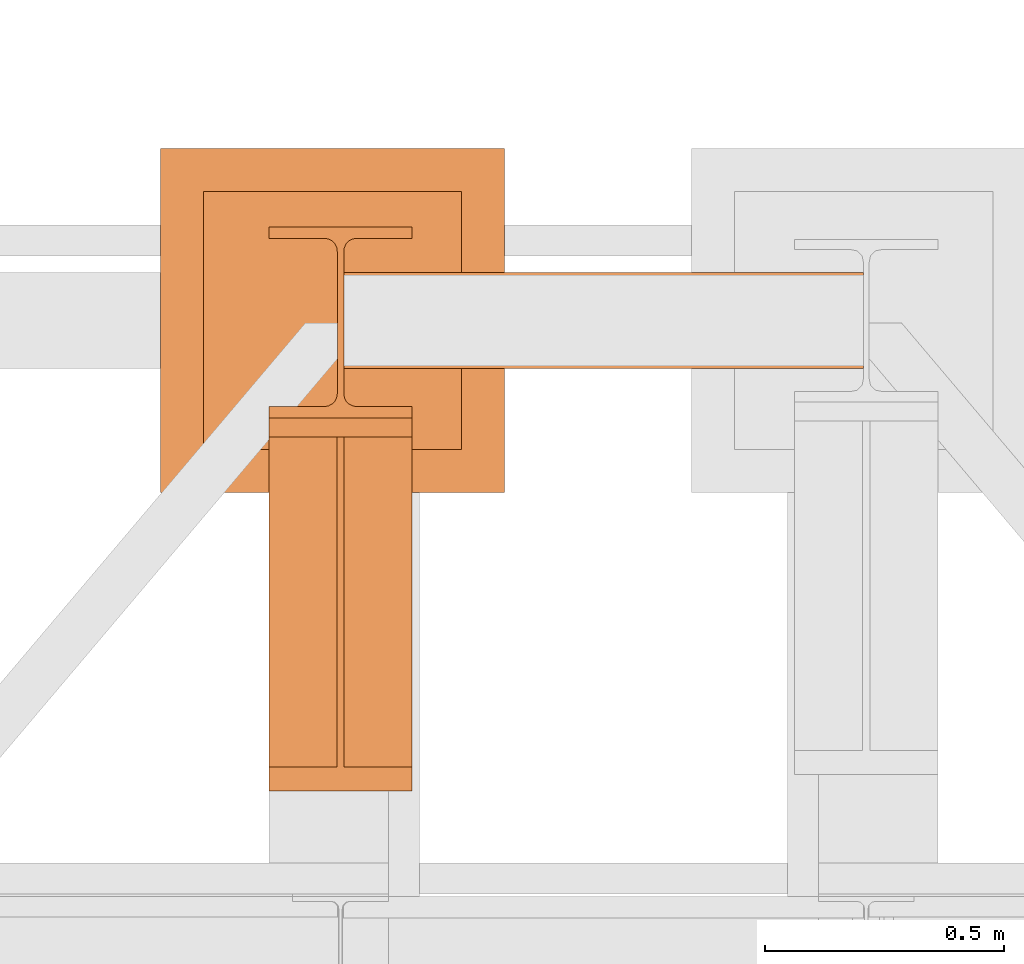
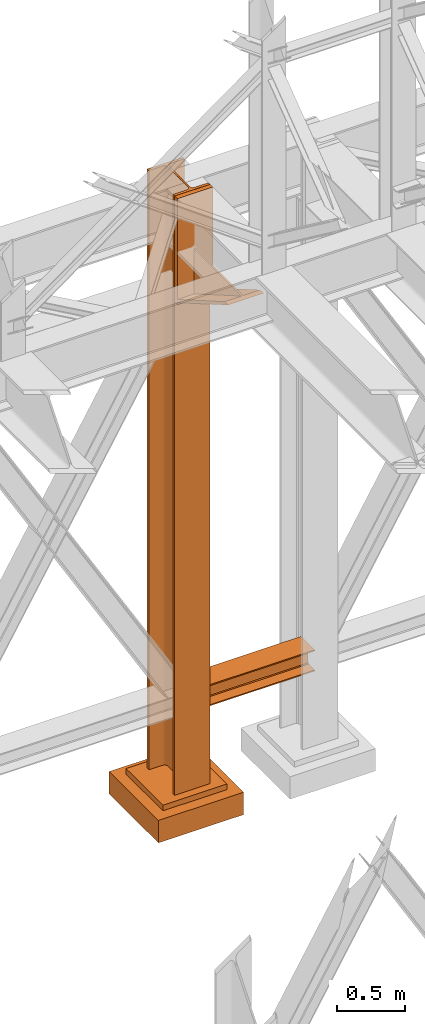
# One storey, part 141 of 208: 4 proxies.
"""IFC2X3 building model written with IfcOpenShell, lengths in millimetres."""

from ifc_helpers import new_model, entity, si_unit, converted_unit, frame, origin, origin_with_axes, place, context, subcontext, project, spatial, faceted_brep, element, save


model = new_model("IFC2X3")

# Units and contexts
model_context = context("Model", 3, precision=1e-05, world=origin())
plan_context = context("Plan", 3, precision=1e-05, world=origin())
body_context = subcontext(model_context, "Body", "Model", "MODEL_VIEW")
ifc_project = project(units=[si_unit("LENGTHUNIT", "METRE", prefix="MILLI"), converted_unit("PLANEANGLEUNIT", "DEGREE", entity("IfcPlaneAngleMeasure", 0.0174532925199433), si_unit("PLANEANGLEUNIT", "RADIAN"), dimensions=[0, 0, 0, 0, 0, 0, 0]), si_unit("AREAUNIT", "SQUARE_METRE"), si_unit("VOLUMEUNIT", "CUBIC_METRE")], contexts=[model_context, plan_context])

# Building, storey
building_placement = place(None, origin())
building = spatial("IfcBuilding", under=ifc_project, at=building_placement, CompositionType="COMPLEX")
storey_placement = place(building_placement, origin_with_axes())
storey = spatial("IfcBuildingStorey", under=building, at=storey_placement, Name="Geschoss", CompositionType="ELEMENT")

# Proxies
proxy_1_placement = place(storey_placement, frame((2199.254968580822, -12562.57439501763, 544.9900024165573), z_axis=(0.0, 0.0, 1.0), x_axis=(1.0, 0.0, 0.0)))
element("IfcBuildingElementProxy", 1, at=proxy_1_placement, inside=storey, context=body_context, shape_type="Brep", body=[
    faceted_brep([(1088.009999895692, 0.01000000000021828, 190.0100125169755), (1088.009999895692, 200.0100029802325, 190.0100125169755), (1088.009999895692, 200.0100029802325, 180.0100146031381), (1088.009999895692, 121.2600035762789, 180.0100071525575), (1088.009999895692, 111.9441915473344, 178.1454621052743), (1088.009999895692, 105.1245498640838, 171.3258190250398), (1088.009999895692, 103.2600015571716, 162.0100079274179), (1088.009999895692, 103.2600015571716, 28.00999713897716), (1088.009999895692, 105.1245498640838, 18.69418604135524), (1088.009999895692, 111.9441915473344, 11.87454296112071), (1088.009999895692, 121.2600035762789, 10.00999791383754), (1088.009999895692, 200.0100029802325, 10.00999791383754), (1088.009999895692, 200.0100029802325, 0.01000000000010459), (1088.009999895692, 0.01000000000021828, 0.01000000000010459), (1088.009999895692, 0.01000000000021828, 10.00999791383754), (1088.009999895692, 78.75999940395377, 10.00999791383754), (1088.009999895692, 88.07581143289826, 11.87454296112071), (1088.009999895692, 94.89545311614893, 18.69418604135524), (1088.009999895692, 96.76000142306111, 28.00999713897716), (1088.009999895692, 96.76000142306111, 162.0100079274179), (1088.009999895692, 94.89545311614893, 171.3258190250398), (1088.009999895692, 88.07581143289826, 178.1454621052743), (1088.009999895692, 78.75999940395377, 180.0100071525575), (1088.009999895692, 0.01000000000021828, 180.0100146031381), (1088.009999895692, 200.0100029802325, 190.0100125169755), (1088.009999895692, 0.01000000000021828, 190.0100125169755), (0.01000000000021828, 0.01000000000021828, 190.0100125169754), (0.01000000000021828, 200.0100029802325, 190.0100125169754), (1088.009999895692, 200.0100029802325, 180.0100146031381), (1088.009999895692, 200.0100029802325, 190.0100125169755), (0.01000000000021828, 200.0100029802325, 190.0100125169754), (0.01000000000021828, 200.0100029802325, 180.010014603138), (1088.009999895692, 121.2600035762789, 180.0100071525575), (1088.009999895692, 200.0100029802325, 180.0100146031381), (0.01000000000021828, 200.0100029802325, 180.010014603138), (0.01000000000021828, 121.2600035762789, 180.0100071525574), (1088.009999895692, 111.9441915473344, 178.1454621052743), (1088.009999895692, 121.2600035762789, 180.0100071525575), (0.01000000000021828, 121.2600035762789, 180.0100071525574), (0.01000000000021828, 111.9441915473344, 178.1454621052742), (1088.009999895692, 105.1245498640838, 171.3258190250398), (1088.009999895692, 111.9441915473344, 178.1454621052743), (0.01000000000021828, 111.9441915473344, 178.1454621052742), (0.01000000000021828, 105.1245498640838, 171.3258190250397), (1088.009999895692, 103.2600015571716, 162.0100079274179), (1088.009999895692, 105.1245498640838, 171.3258190250398), (0.01000000000021828, 105.1245498640838, 171.3258190250397), (0.01000000000021828, 103.2600015571716, 162.0100079274178), (1088.009999895692, 103.2600015571716, 28.00999713897716), (1088.009999895692, 103.2600015571716, 162.0100079274179), (0.01000000000021828, 103.2600015571716, 162.0100079274178), (0.01000000000021828, 103.2600015571716, 28.00999713897704), (1088.009999895692, 105.1245498640838, 18.69418604135524), (1088.009999895692, 103.2600015571716, 28.00999713897716), (0.01000000000021828, 103.2600015571716, 28.00999713897704), (0.01000000000021828, 105.1245498640838, 18.69418604135512), (1088.009999895692, 111.9441915473344, 11.87454296112071), (1088.009999895692, 105.1245498640838, 18.69418604135524), (0.01000000000021828, 105.1245498640838, 18.69418604135512), (0.01000000000021828, 111.9441915473344, 11.8745429611206), (1088.009999895692, 121.2600035762789, 10.00999791383754), (1088.009999895692, 111.9441915473344, 11.87454296112071), (0.01000000000021828, 111.9441915473344, 11.8745429611206), (0.01000000000021828, 121.2600035762789, 10.00999791383742), (1088.009999895692, 200.0100029802325, 10.00999791383754), (1088.009999895692, 121.2600035762789, 10.00999791383754), (0.01000000000021828, 121.2600035762789, 10.00999791383742), (0.01000000000021828, 200.0100029802325, 10.00999791383742), (1088.009999895692, 200.0100029802325, 0.01000000000010459), (1088.009999895692, 200.0100029802325, 10.00999791383754), (0.01000000000021828, 200.0100029802325, 10.00999791383742), (0.01000000000021828, 200.0100029802325, 0.009999999999990905), (1088.009999895692, 0.01000000000021828, 0.01000000000010459), (1088.009999895692, 200.0100029802325, 0.01000000000010459), (0.01000000000021828, 200.0100029802325, 0.009999999999990905), (0.01000000000021828, 0.01000000000021828, 0.009999999999990905), (1088.009999895692, 0.01000000000021828, 10.00999791383754), (1088.009999895692, 0.01000000000021828, 0.01000000000010459), (0.01000000000021828, 0.01000000000021828, 0.009999999999990905), (0.01000000000021828, 0.01000000000021828, 10.00999791383742), (1088.009999895692, 78.75999940395377, 10.00999791383754), (1088.009999895692, 0.01000000000021828, 10.00999791383754), (0.01000000000021828, 0.01000000000021828, 10.00999791383742), (0.01000000000021828, 78.75999940395377, 10.00999791383742), (1088.009999895692, 88.07581143289826, 11.87454296112071), (1088.009999895692, 78.75999940395377, 10.00999791383754), (0.01000000000021828, 78.75999940395377, 10.00999791383742), (0.01000000000021828, 88.07581143289826, 11.8745429611206), (1088.009999895692, 94.89545311614893, 18.69418604135524), (1088.009999895692, 88.07581143289826, 11.87454296112071), (0.01000000000021828, 88.07581143289826, 11.8745429611206), (0.01000000000021828, 94.89545311614893, 18.69418604135512), (1088.009999895692, 96.76000142306111, 28.00999713897716), (1088.009999895692, 94.89545311614893, 18.69418604135524), (0.01000000000021828, 94.89545311614893, 18.69418604135512), (0.01000000000021828, 96.76000142306111, 28.00999713897704), (1088.009999895692, 96.76000142306111, 162.0100079274179), (1088.009999895692, 96.76000142306111, 28.00999713897716), (0.01000000000021828, 96.76000142306111, 28.00999713897704), (0.01000000000021828, 96.76000142306111, 162.0100079274178), (1088.009999895692, 94.89545311614893, 171.3258190250398), (1088.009999895692, 96.76000142306111, 162.0100079274179), (0.01000000000021828, 96.76000142306111, 162.0100079274178), (0.01000000000021828, 94.89545311614893, 171.3258190250397), (1088.009999895692, 88.07581143289826, 178.1454621052743), (1088.009999895692, 94.89545311614893, 171.3258190250398), (0.01000000000021828, 94.89545311614893, 171.3258190250397), (0.01000000000021828, 88.07581143289826, 178.1454621052742), (1088.009999895692, 78.75999940395377, 180.0100071525575), (1088.009999895692, 88.07581143289826, 178.1454621052743), (0.01000000000021828, 88.07581143289826, 178.1454621052742), (0.01000000000021828, 78.75999940395377, 180.0100071525574), (1088.009999895692, 0.01000000000021828, 180.0100146031381), (1088.009999895692, 78.75999940395377, 180.0100071525575), (0.01000000000021828, 78.75999940395377, 180.0100071525574), (0.01000000000021828, 0.01000000000021828, 180.010014603138), (1088.009999895692, 0.01000000000021828, 190.0100125169755), (1088.009999895692, 0.01000000000021828, 180.0100146031381), (0.01000000000021828, 0.01000000000021828, 180.010014603138), (0.01000000000021828, 0.01000000000021828, 190.0100125169754), (0.01000000000021828, 0.01000000000021828, 190.0100125169754), (0.01000000000021828, 0.01000000000021828, 180.010014603138), (0.01000000000021828, 78.75999940395377, 180.0100071525574), (0.01000000000021828, 88.07581143289826, 178.1454621052742), (0.01000000000021828, 94.89545311614893, 171.3258190250397), (0.01000000000021828, 96.76000142306111, 162.0100079274178), (0.01000000000021828, 96.76000142306111, 28.00999713897704), (0.01000000000021828, 94.89545311614893, 18.69418604135512), (0.01000000000021828, 88.07581143289826, 11.8745429611206), (0.01000000000021828, 78.75999940395377, 10.00999791383742), (0.01000000000021828, 0.01000000000021828, 10.00999791383742), (0.01000000000021828, 0.01000000000021828, 0.009999999999990905), (0.01000000000021828, 200.0100029802325, 0.009999999999990905), (0.01000000000021828, 200.0100029802325, 10.00999791383742), (0.01000000000021828, 121.2600035762789, 10.00999791383742), (0.01000000000021828, 111.9441915473344, 11.8745429611206), (0.01000000000021828, 105.1245498640838, 18.69418604135512), (0.01000000000021828, 103.2600015571716, 28.00999713897704), (0.01000000000021828, 103.2600015571716, 162.0100079274178), (0.01000000000021828, 105.1245498640838, 171.3258190250397), (0.01000000000021828, 111.9441915473344, 178.1454621052742), (0.01000000000021828, 121.2600035762789, 180.0100071525574), (0.01000000000021828, 200.0100029802325, 180.010014603138), (0.01000000000021828, 200.0100029802325, 190.0100125169754)], [[[0, 1, 2, 3, 4, 5, 6, 7, 8, 9, 10, 11, 12, 13, 14, 15, 16, 17, 18, 19, 20, 21, 22, 23]], [[24, 25, 26, 27]], [[28, 29, 30, 31]], [[32, 33, 34, 35]], [[36, 37, 38, 39]], [[40, 41, 42, 43]], [[44, 45, 46, 47]], [[48, 49, 50, 51]], [[52, 53, 54, 55]], [[56, 57, 58, 59]], [[60, 61, 62, 63]], [[64, 65, 66, 67]], [[68, 69, 70, 71]], [[72, 73, 74, 75]], [[76, 77, 78, 79]], [[80, 81, 82, 83]], [[84, 85, 86, 87]], [[88, 89, 90, 91]], [[92, 93, 94, 95]], [[96, 97, 98, 99]], [[100, 101, 102, 103]], [[104, 105, 106, 107]], [[108, 109, 110, 111]], [[112, 113, 114, 115]], [[116, 117, 118, 119]], [[120, 121, 122, 123, 124, 125, 126, 127, 128, 129, 130, 131, 132, 133, 134, 135, 136, 137, 138, 139, 140, 141, 142, 143]]], orient=[[False], [False], [False], [False], [False], [False], [False], [False], [False], [False], [False], [False], [False], [False], [False], [False], [False], [False], [False], [False], [False], [False], [False], [False], [False], [False]]),
])
proxy_2_placement = place(storey_placement, frame((1816.730231152621, -12822.57439725281, -315.0099999999999), z_axis=(0.0, 0.0, 1.0), x_axis=(1.0, 0.0, 0.0)))
element("IfcBuildingElementProxy", 2, at=proxy_2_placement, inside=storey, context=body_context, shape_type="Brep", body=[
    faceted_brep([(630.01, 630.0100000000002, 250.01), (630.01, 90.01000000000022, 250.01), (90.00999999999999, 90.01000000000022, 250.01), (90.00999999999999, 630.0100000000002, 250.01), (630.01, 630.0100000000002, 200.01), (630.01, 90.01000000000022, 200.01), (630.01, 90.01000000000022, 250.01), (630.01, 630.0100000000002, 250.01), (90.00999999999999, 630.0100000000002, 200.01), (630.01, 630.0100000000002, 200.01), (630.01, 630.0100000000002, 250.01), (90.00999999999999, 630.0100000000002, 250.01), (90.00999999999999, 90.01000000000022, 200.01), (90.00999999999999, 630.0100000000002, 200.01), (90.00999999999999, 630.0100000000002, 250.01), (90.00999999999999, 90.01000000000022, 250.01), (630.01, 90.01000000000022, 200.01), (90.00999999999999, 90.01000000000022, 200.01), (90.00999999999999, 90.01000000000022, 250.01), (630.01, 90.01000000000022, 250.01), (720.01, 0.01000000000021828, 0.009999999999990905), (720.01, 720.0100000000002, 0.009999999999990905), (0.009999999999990905, 720.0100000000002, 0.009999999999990905), (0.009999999999990905, 0.01000000000021828, 0.009999999999990905), (720.01, 720.0100000000002, 200.01), (720.01, 0.01000000000021828, 200.01), (0.009999999999990905, 0.01000000000021828, 200.01), (0.009999999999990905, 720.0100000000002, 200.01), (90.00999999999999, 90.01000000000022, 200.01), (630.01, 90.01000000000022, 200.01), (630.01, 630.0100000000002, 200.01), (90.00999999999999, 630.0100000000002, 200.01), (720.01, 720.0100000000002, 0.009999999999990905), (720.01, 0.01000000000021828, 0.009999999999990905), (720.01, 0.01000000000021828, 200.01), (720.01, 720.0100000000002, 200.01), (0.009999999999990905, 720.0100000000002, 0.009999999999990905), (720.01, 720.0100000000002, 0.009999999999990905), (720.01, 720.0100000000002, 200.01), (0.009999999999990905, 720.0100000000002, 200.01), (0.009999999999990905, 0.01000000000021828, 0.009999999999990905), (0.009999999999990905, 720.0100000000002, 0.009999999999990905), (0.009999999999990905, 720.0100000000002, 200.01), (0.009999999999990905, 0.01000000000021828, 200.01), (720.01, 0.01000000000021828, 0.009999999999990905), (0.009999999999990905, 0.01000000000021828, 0.009999999999990905), (0.009999999999990905, 0.01000000000021828, 200.01), (720.01, 0.01000000000021828, 200.01)], [[[0, 1, 2, 3]], [[4, 5, 6, 7]], [[8, 9, 10, 11]], [[12, 13, 14, 15]], [[16, 17, 18, 19]], [[20, 21, 22, 23]], [[24, 25, 26, 27], [28, 29, 30, 31]], [[32, 33, 34, 35]], [[36, 37, 38, 39]], [[40, 41, 42, 43]], [[44, 45, 46, 47]]], orient=[[False], [False], [False], [False], [False], [False], [False, False], [False], [False], [False], [False]]),
])
proxy_3_placement = place(storey_placement, frame((2043.254968528667, -12666.57439173938, -65.01000000000022), z_axis=(0.0, 0.0, 1.0), x_axis=(1.0, 0.0, 0.0)))
element("IfcBuildingElementProxy", 3, at=proxy_3_placement, inside=storey, Name="3D Element", context=body_context, shape_type="Brep", body=[
    faceted_brep([(0.009999999999990905, 400.0100000000002, 5350.010005364416), (300.01, 400.0100000000002, 5350.010005364416), (300.01, 376.0100000000002, 5350.010005364416), (183.76, 376.0100000000002, 5350.010005364416), (175.4165694541391, 374.6884339422595, 5350.010005364416), (167.8898249341985, 370.8534254634014, 5350.010005364416), (161.9165745365979, 364.8801750658004, 5350.010005364416), (157.9269689743871, 356.3774142355142, 5350.010005364416), (156.76, 349.0100000000002, 5350.010005364416), (156.76, 51.01000000000022, 5350.010005364416), (158.0815660577403, 42.66656945413888, 5350.010005364416), (161.9165745365979, 35.13982493419826, 5350.010005364416), (167.8898249341985, 29.16657453659718, 5350.010005364416), (175.4165694541391, 25.33156605774093, 5350.010005364416), (183.76, 24.01000000000022, 5350.010005364416), (300.01, 24.01000000000022, 5350.010005364416), (300.01, 0.01000000000021828, 5350.010005364416), (0.009999999999990905, 0.01000000000021828, 5350.010005364416), (0.009999999999990905, 24.01000000000022, 5350.010005364416), (116.26, 24.01000000000022, 5350.010005364416), (124.6034305458604, 25.33156605774093, 5350.010005364416), (132.1301750658015, 29.16657453659718, 5350.010005364416), (138.1034254634017, 35.13982493419826, 5350.010005364416), (141.9384339422597, 42.66656945413888, 5350.010005364416), (143.26, 51.01000000000022, 5350.010005364416), (143.26, 347.9786887785685, 5350.010005364416), (141.9384339422597, 357.3534305458597, 5350.010005364416), (138.1034254634021, 364.8801750658004, 5350.010005364416), (132.1301750658015, 370.8534254634014, 5350.010005364416), (124.6034305458604, 374.6884339422595, 5350.010005364416), (115.0308095164803, 376.0100000000002, 5350.010005364416), (0.009999999999990905, 376.0100000000002, 5350.010005364416), (300.01, 400.0100000000002, 5350.010005364416), (0.009999999999990905, 400.0100000000002, 5350.010005364416), (0.009999999999990905, 400.0100000000002, 0.01000000000021828), (300.01, 400.0100000000002, 0.01000000000021828), (300.01, 376.0100000000002, 5350.010005364416), (300.01, 400.0100000000002, 5350.010005364416), (300.01, 400.0100000000002, 0.01000000000021828), (300.01, 376.0100000000002, 0.01000000000021828), (183.76, 376.0100000000002, 5350.010005364416), (300.01, 376.0100000000002, 5350.010005364416), (300.01, 376.0100000000002, 0.01000000000021828), (183.76, 376.0100000000002, 0.01000000000021828), (175.4165694541391, 374.6884339422595, 5350.010005364416), (183.76, 376.0100000000002, 5350.010005364416), (183.76, 376.0100000000002, 0.01000000000021828), (175.4165694541391, 374.6884339422595, 0.01000000000021828), (167.8898249341985, 370.8534254634014, 5350.010005364416), (175.4165694541391, 374.6884339422595, 5350.010005364416), (175.4165694541391, 374.6884339422595, 0.01000000000021828), (167.8898249341985, 370.8534254634014, 0.01000000000021828), (161.9165745365979, 364.8801750658004, 5350.010005364416), (167.8898249341985, 370.8534254634014, 5350.010005364416), (167.8898249341985, 370.8534254634014, 0.01000000000021828), (161.9165745365979, 364.8801750658004, 0.01000000000021828), (157.9269689743871, 356.3774142355142, 5350.010005364416), (161.9165745365979, 364.8801750658004, 5350.010005364416), (161.9165745365979, 364.8801750658004, 0.01000000000021828), (157.9269689743871, 356.3774142355142, 0.01000000000021828), (156.76, 349.0100000000002, 5350.010005364416), (157.9269689743871, 356.3774142355142, 5350.010005364416), (157.9269689743871, 356.3774142355142, 0.01000000000021828), (156.76, 349.0100000000002, 0.01000000000021828), (156.76, 51.01000000000022, 5350.010005364416), (156.76, 349.0100000000002, 5350.010005364416), (156.76, 349.0100000000002, 0.01000000000021828), (156.76, 51.01000000000022, 0.01000000000021828), (158.0815660577403, 42.66656945413888, 5350.010005364416), (156.76, 51.01000000000022, 5350.010005364416), (156.76, 51.01000000000022, 0.01000000000021828), (158.0815660577403, 42.66656945413888, 0.01000000000021828), (161.9165745365979, 35.13982493419826, 5350.010005364416), (158.0815660577403, 42.66656945413888, 5350.010005364416), (158.0815660577403, 42.66656945413888, 0.01000000000021828), (161.9165745365979, 35.13982493419826, 0.01000000000021828), (167.8898249341985, 29.16657453659718, 5350.010005364416), (161.9165745365979, 35.13982493419826, 5350.010005364416), (161.9165745365979, 35.13982493419826, 0.01000000000021828), (167.8898249341985, 29.16657453659718, 0.01000000000021828), (175.4165694541391, 25.33156605774093, 5350.010005364416), (167.8898249341985, 29.16657453659718, 5350.010005364416), (167.8898249341985, 29.16657453659718, 0.01000000000021828), (175.4165694541391, 25.33156605774093, 0.01000000000021828), (183.76, 24.01000000000022, 5350.010005364416), (175.4165694541391, 25.33156605774093, 5350.010005364416), (175.4165694541391, 25.33156605774093, 0.01000000000021828), (183.76, 24.01000000000022, 0.01000000000021828), (300.01, 24.01000000000022, 5350.010005364416), (183.76, 24.01000000000022, 5350.010005364416), (183.76, 24.01000000000022, 0.01000000000021828), (300.01, 24.01000000000022, 0.01000000000021828), (300.01, 0.01000000000021828, 5350.010005364416), (300.01, 24.01000000000022, 5350.010005364416), (300.01, 24.01000000000022, 0.01000000000021828), (300.01, 0.01000000000021828, 0.01000000000021828), (0.009999999999990905, 0.01000000000021828, 5350.010005364416), (300.01, 0.01000000000021828, 5350.010005364416), (300.01, 0.01000000000021828, 0.01000000000021828), (0.009999999999990905, 0.01000000000021828, 0.01000000000021828), (0.009999999999990905, 24.01000000000022, 5350.010005364416), (0.009999999999990905, 0.01000000000021828, 5350.010005364416), (0.009999999999990905, 0.01000000000021828, 0.01000000000021828), (0.009999999999990905, 24.01000000000022, 0.01000000000021828), (116.26, 24.01000000000022, 5350.010005364416), (0.009999999999990905, 24.01000000000022, 5350.010005364416), (0.009999999999990905, 24.01000000000022, 0.01000000000021828), (116.26, 24.01000000000022, 0.01000000000021828), (124.6034305458604, 25.33156605774093, 5350.010005364416), (116.26, 24.01000000000022, 5350.010005364416), (116.26, 24.01000000000022, 0.01000000000021828), (124.6034305458604, 25.33156605774093, 0.01000000000021828), (132.1301750658015, 29.16657453659718, 5350.010005364416), (124.6034305458604, 25.33156605774093, 5350.010005364416), (124.6034305458604, 25.33156605774093, 0.01000000000021828), (132.1301750658015, 29.16657453659718, 0.01000000000021828), (138.1034254634017, 35.13982493419826, 5350.010005364416), (132.1301750658015, 29.16657453659718, 5350.010005364416), (132.1301750658015, 29.16657453659718, 0.01000000000021828), (138.1034254634017, 35.13982493419826, 0.01000000000021828), (141.9384339422597, 42.66656945413888, 5350.010005364416), (138.1034254634017, 35.13982493419826, 5350.010005364416), (138.1034254634017, 35.13982493419826, 0.01000000000021828), (141.9384339422597, 42.66656945413888, 0.01000000000021828), (143.26, 51.01000000000022, 5350.010005364416), (141.9384339422597, 42.66656945413888, 5350.010005364416), (141.9384339422597, 42.66656945413888, 0.01000000000021828), (143.26, 51.01000000000022, 0.01000000000021828), (143.26, 347.9786887785685, 5350.010005364416), (143.26, 51.01000000000022, 5350.010005364416), (143.26, 51.01000000000022, 0.01000000000021828), (143.26, 347.9786887785685, 0.01000000000021828), (141.9384339422597, 357.3534305458597, 5350.010005364416), (143.26, 347.9786887785685, 5350.010005364416), (143.26, 347.9786887785685, 0.01000000000021828), (141.9384339422597, 357.3534305458597, 0.01000000000021828), (138.1034254634021, 364.8801750658004, 5350.010005364416), (141.9384339422597, 357.3534305458597, 5350.010005364416), (141.9384339422597, 357.3534305458597, 0.01000000000021828), (138.1034254634021, 364.8801750658004, 0.01000000000021828), (132.1301750658015, 370.8534254634014, 5350.010005364416), (138.1034254634021, 364.8801750658004, 5350.010005364416), (138.1034254634021, 364.8801750658004, 0.01000000000021828), (132.1301750658015, 370.8534254634014, 0.01000000000021828), (124.6034305458604, 374.6884339422595, 5350.010005364416), (132.1301750658015, 370.8534254634014, 5350.010005364416), (132.1301750658015, 370.8534254634014, 0.01000000000021828), (124.6034305458604, 374.6884339422595, 0.01000000000021828), (115.0308095164803, 376.0100000000002, 5350.010005364416), (124.6034305458604, 374.6884339422595, 5350.010005364416), (124.6034305458604, 374.6884339422595, 0.01000000000021828), (115.0308095164803, 376.0100000000002, 0.01000000000021828), (0.009999999999990905, 376.0100000000002, 5350.010005364416), (115.0308095164803, 376.0100000000002, 5350.010005364416), (115.0308095164803, 376.0100000000002, 0.01000000000021828), (0.009999999999990905, 376.0100000000002, 0.01000000000021828), (0.009999999999990905, 400.0100000000002, 5350.010005364416), (0.009999999999990905, 376.0100000000002, 5350.010005364416), (0.009999999999990905, 376.0100000000002, 0.01000000000021828), (0.009999999999990905, 400.0100000000002, 0.01000000000021828), (0.009999999999990905, 400.0100000000002, 0.01000000000021828), (0.009999999999990905, 376.0100000000002, 0.01000000000021828), (115.0308095164803, 376.0100000000002, 0.01000000000021828), (124.6034305458604, 374.6884339422595, 0.01000000000021828), (132.1301750658015, 370.8534254634014, 0.01000000000021828), (138.1034254634021, 364.8801750658004, 0.01000000000021828), (141.9384339422597, 357.3534305458597, 0.01000000000021828), (143.26, 347.9786887785685, 0.01000000000021828), (143.26, 51.01000000000022, 0.01000000000021828), (141.9384339422597, 42.66656945413888, 0.01000000000021828), (138.1034254634017, 35.13982493419826, 0.01000000000021828), (132.1301750658015, 29.16657453659718, 0.01000000000021828), (124.6034305458604, 25.33156605774093, 0.01000000000021828), (116.26, 24.01000000000022, 0.01000000000021828), (0.009999999999990905, 24.01000000000022, 0.01000000000021828), (0.009999999999990905, 0.01000000000021828, 0.01000000000021828), (300.01, 0.01000000000021828, 0.01000000000021828), (300.01, 24.01000000000022, 0.01000000000021828), (183.76, 24.01000000000022, 0.01000000000021828), (175.4165694541391, 25.33156605774093, 0.01000000000021828), (167.8898249341985, 29.16657453659718, 0.01000000000021828), (161.9165745365979, 35.13982493419826, 0.01000000000021828), (158.0815660577403, 42.66656945413888, 0.01000000000021828), (156.76, 51.01000000000022, 0.01000000000021828), (156.76, 349.0100000000002, 0.01000000000021828), (157.9269689743871, 356.3774142355142, 0.01000000000021828), (161.9165745365979, 364.8801750658004, 0.01000000000021828), (167.8898249341985, 370.8534254634014, 0.01000000000021828), (175.4165694541391, 374.6884339422595, 0.01000000000021828), (183.76, 376.0100000000002, 0.01000000000021828), (300.01, 376.0100000000002, 0.01000000000021828), (300.01, 400.0100000000002, 0.01000000000021828)], [[[0, 1, 2, 3, 4, 5, 6, 7, 8, 9, 10, 11, 12, 13, 14, 15, 16, 17, 18, 19, 20, 21, 22, 23, 24, 25, 26, 27, 28, 29, 30, 31]], [[32, 33, 34, 35]], [[36, 37, 38, 39]], [[40, 41, 42, 43]], [[44, 45, 46, 47]], [[48, 49, 50, 51]], [[52, 53, 54, 55]], [[56, 57, 58, 59]], [[60, 61, 62, 63]], [[64, 65, 66, 67]], [[68, 69, 70, 71]], [[72, 73, 74, 75]], [[76, 77, 78, 79]], [[80, 81, 82, 83]], [[84, 85, 86, 87]], [[88, 89, 90, 91]], [[92, 93, 94, 95]], [[96, 97, 98, 99]], [[100, 101, 102, 103]], [[104, 105, 106, 107]], [[108, 109, 110, 111]], [[112, 113, 114, 115]], [[116, 117, 118, 119]], [[120, 121, 122, 123]], [[124, 125, 126, 127]], [[128, 129, 130, 131]], [[132, 133, 134, 135]], [[136, 137, 138, 139]], [[140, 141, 142, 143]], [[144, 145, 146, 147]], [[148, 149, 150, 151]], [[152, 153, 154, 155]], [[156, 157, 158, 159]], [[160, 161, 162, 163, 164, 165, 166, 167, 168, 169, 170, 171, 172, 173, 174, 175, 176, 177, 178, 179, 180, 181, 182, 183, 184, 185, 186, 187, 188, 189, 190, 191]]], orient=[[False], [False], [False], [False], [False], [False], [False], [False], [False], [False], [False], [False], [False], [False], [False], [False], [False], [False], [False], [False], [False], [False], [False], [False], [False], [False], [False], [False], [False], [False], [False], [False], [False], [False]]),
])
proxy_4_placement = place(storey_placement, frame((2043.254968528667, -13446.43639173938, 4339.230005364416), z_axis=(0.0, 0.0, 1.0), x_axis=(1.0, 0.0, 0.0)))
element("IfcBuildingElementProxy", 4, at=proxy_4_placement, inside=storey, context=body_context, shape_type="Brep", body=[
    faceted_brep([(0.009999999999990905, 739.8719999999976, 18.61000000000058), (0.009999999999990905, 0.00999999999839929, 445.7700000000004), (300.01, 0.00999999999839929, 445.7700000000004), (300.01, 739.8719999999976, 18.61000000000058), (0.009999999999990905, 0.00999999999839929, 445.7700000000004), (0.009999999999990905, 50.06599999999708, 445.7710000000006), (142.51, 50.06599999999708, 445.7710000000006), (157.51, 50.06599999999708, 445.7710000000006), (300.01, 50.06599999999708, 445.7710000000006), (300.01, 0.00999999999839929, 445.7700000000004), (0.009999999999990905, 50.06599999999708, 445.7710000000006), (0.009999999999990905, 739.8719999999976, 47.51000000000022), (142.51, 739.8719999999976, 47.51000000000022), (142.51, 50.06599999999708, 445.7710000000006), (157.51, 739.8719999999976, 47.51000000000022), (300.01, 739.8719999999976, 47.51000000000022), (300.01, 50.06599999999708, 445.7710000000006), (157.51, 50.06599999999708, 445.7710000000006), (0.009999999999990905, 739.8719999999976, 18.61000000000058), (0.009999999999990905, 739.8719999999976, 0.01000000000021828), (0.009999999999990905, 779.8719999999976, 0.01000000000021828), (0.009999999999990905, 779.8719999999976, 945.7700000000004), (0.009999999999990905, 739.8719999999976, 945.7700000000004), (0.009999999999990905, 739.8719999999976, 47.51000000000022), (0.009999999999990905, 50.06599999999708, 445.7710000000006), (0.009999999999990905, 0.00999999999839929, 445.7700000000004), (300.01, 779.8719999999976, 945.7700000000004), (300.01, 779.8719999999976, 0.01000000000021828), (300.01, 739.8719999999976, 0.01000000000021828), (300.01, 739.8719999999976, 18.61000000000058), (300.01, 0.00999999999839929, 445.7700000000004), (300.01, 50.06599999999708, 445.7710000000006), (300.01, 739.8719999999976, 47.51000000000022), (300.01, 739.8719999999976, 945.7700000000004), (300.01, 779.8719999999976, 945.7700000000004), (300.01, 739.8719999999976, 945.7700000000004), (0.009999999999990905, 739.8719999999976, 945.7700000000004), (0.009999999999990905, 779.8719999999976, 945.7700000000004), (300.01, 739.8719999999976, 945.7700000000004), (300.01, 739.8719999999976, 47.51000000000022), (157.51, 739.8719999999976, 47.51000000000022), (157.51, 739.8719999999976, 445.7700000000004), (142.51, 739.8719999999976, 445.7700000000004), (142.51, 739.8719999999976, 47.51000000000022), (0.009999999999990905, 739.8719999999976, 47.51000000000022), (0.009999999999990905, 739.8719999999976, 945.7700000000004), (300.01, 739.8719999999976, 18.61000000000058), (300.01, 739.8719999999976, 0.01000000000021828), (0.009999999999990905, 739.8719999999976, 0.01000000000021828), (0.009999999999990905, 739.8719999999976, 18.61000000000058), (300.01, 739.8719999999976, 0.01000000000021828), (300.01, 779.8719999999976, 0.01000000000021828), (0.009999999999990905, 779.8719999999976, 0.01000000000021828), (0.009999999999990905, 739.8719999999976, 0.01000000000021828), (300.01, 779.8719999999976, 0.01000000000021828), (300.01, 779.8719999999976, 945.7700000000004), (0.009999999999990905, 779.8719999999976, 945.7700000000004), (0.009999999999990905, 779.8719999999976, 0.01000000000021828), (142.51, 50.06599999999708, 445.7710000000006), (142.51, 739.8719999999976, 445.7700000000004), (157.51, 739.8719999999976, 445.7700000000004), (157.51, 50.06599999999708, 445.7710000000006), (142.51, 739.8719999999976, 47.51000000000022), (142.51, 739.8719999999976, 445.7700000000004), (142.51, 50.06599999999708, 445.7710000000006), (157.51, 739.8719999999976, 47.51000000000022), (157.51, 50.06599999999708, 445.7710000000006), (157.51, 739.8719999999976, 445.7700000000004)], [[[0, 1, 2, 3]], [[4, 5, 6, 7, 8, 9]], [[10, 11, 12, 13]], [[14, 15, 16, 17]], [[18, 19, 20, 21, 22, 23, 24, 25]], [[26, 27, 28, 29, 30, 31, 32, 33]], [[34, 35, 36, 37]], [[38, 39, 40, 41, 42, 43, 44, 45]], [[46, 47, 48, 49]], [[50, 51, 52, 53]], [[54, 55, 56, 57]], [[58, 59, 60, 61]], [[62, 63, 64]], [[65, 66, 67]]], orient=[[False], [False], [False], [False], [False], [False], [False], [False], [False], [False], [False], [False], [False], [False]]),
])

save(model, "model.ifc")
